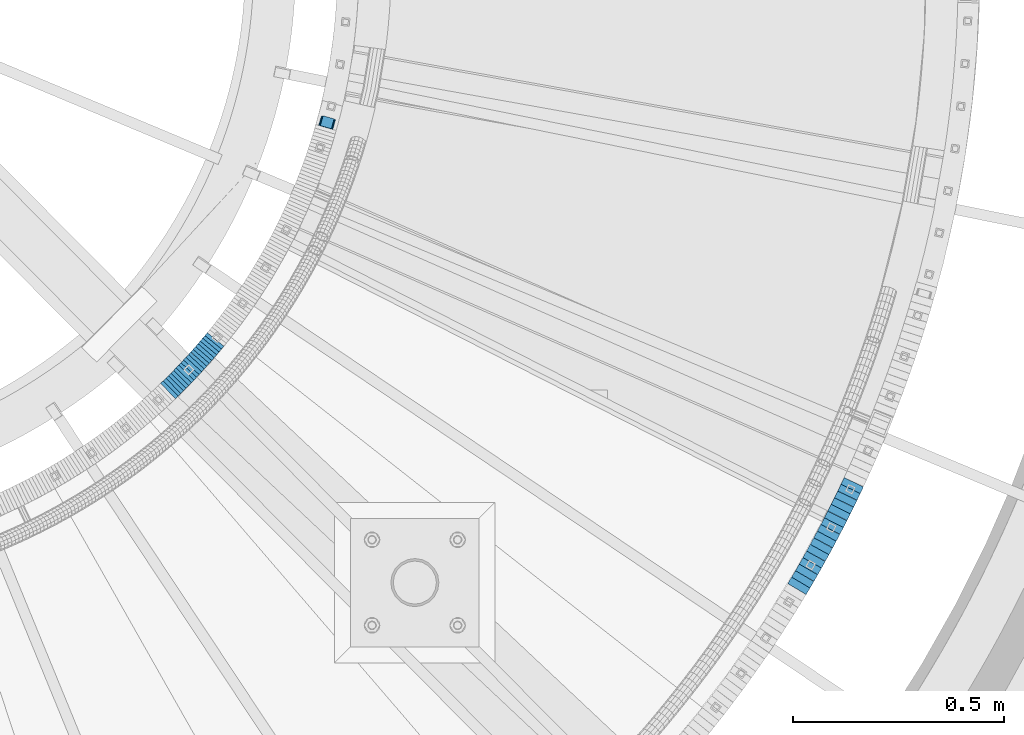
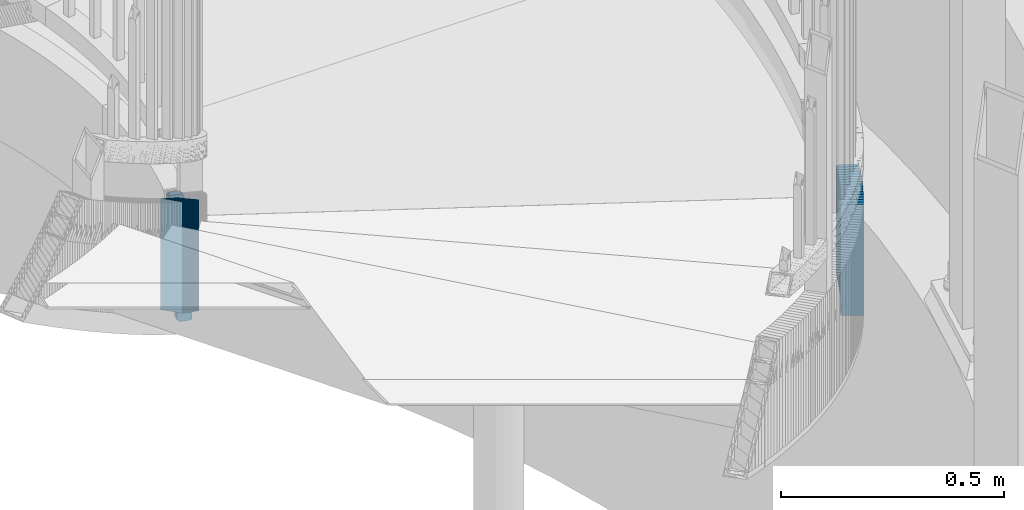
# One storey, part 906 of 975: 36 plates.
"""IFC2X3 building model written with IfcOpenShell, lengths in millimetres."""

from ifc_helpers import new_model, si_unit, frame, origin_with_axes, place, context, subcontext, project, spatial, faceted_brep, material, type_object, element, save


model = new_model("IFC2X3")

# Units and contexts
model_context = context("Model", 3, precision=1e-05, world=origin_with_axes())
body_context = subcontext(model_context, "Body", "Model", "MODEL_VIEW")
ifc_project = project(units=[si_unit("LENGTHUNIT", "METRE", prefix="MILLI"), si_unit("AREAUNIT", "SQUARE_METRE"), si_unit("VOLUMEUNIT", "CUBIC_METRE"), si_unit("MASSUNIT", "GRAM", prefix="KILO"), si_unit("TIMEUNIT", "SECOND"), si_unit("PLANEANGLEUNIT", "RADIAN"), si_unit("SOLIDANGLEUNIT", "STERADIAN"), si_unit("THERMODYNAMICTEMPERATUREUNIT", "DEGREE_CELSIUS"), si_unit("LUMINOUSINTENSITYUNIT", "LUMEN")], contexts=[model_context])

# Site, building, storey
site_placement = place(None, origin_with_axes())
site = spatial("IfcSite", under=ifc_project, at=site_placement, CompositionType="ELEMENT")
building_placement = place(site_placement, origin_with_axes())
building = spatial("IfcBuilding", under=site, at=building_placement, Name="Undefined", CompositionType="ELEMENT")
storey_placement = place(building_placement, origin_with_axes())
storey = spatial("IfcBuildingStorey", under=building, at=storey_placement, Name="Undefined", CompositionType="ELEMENT", Elevation=0.0)

# Plates
ifc_material = material(Name="STEEL/A36")
plate_type_1 = type_object("IfcPlateType", PredefinedType="NOTDEFINED")
plate_1_placement = place(storey_placement, frame((36098.5069484526, 3030.4815809635, 2176.46249923706), z_axis=(-0.0754792401712839, -0.266352390036721, -0.96091585928472), x_axis=(-0.962114570717468, 0.272645470919916, 0.0)))
element("IfcPlate", 1, at=plate_1_placement, inside=storey, type_object=plate_type_1, material=ifc_material, Name="PLATE", context=body_context, shape_type="Brep", body=[
    faceted_brep([(0.0340070923703024, -12.7000000000116, 6.3838263213047), (1.56807923502492, -12.7000000000517, 294.360523289424), (1.56807923496672, 12.6999999999643, 294.360523289415), (0.0340070923120948, 12.7000000000044, 6.38382632129469), (2.06110954808537, -12.7000000000498, 296.780155936494), (2.06110954803444, 12.699999999968, 296.780155936485), (3.4398364631852, -12.7000000000498, 298.828768425464), (3.43983646312699, 12.699999999968, 298.828768425454), (5.49576435648487, -12.700000000048, 300.1965628303), (5.49576435642666, 12.6999999999698, 300.196562830291), (7.91798904242751, -12.7000000000444, 300.676696777382), (7.91798904236202, 12.6999999999716, 300.676696777372), (30.141276409202, -12.7000000000244, 300.676696777376), (30.1412764091438, 12.6999999999916, 300.676696777366), (32.5791100484857, -12.7000000000207, 300.190097416452), (32.5791100484275, 12.6999999999953, 300.190097416442), (34.6433221732077, -12.7000000000189, 298.80487537828), (34.6433221731495, 12.6999999999971, 298.804875378271), (36.0175523689613, -12.7000000000189, 296.733329298654), (36.0175523688958, 12.6999999999989, 296.733329298644), (36.4911866057737, -12.7000000000171, 294.292943591306), (36.4911866057228, 12.7000000000007, 294.292943591297), (34.9604313355012, -12.6999999999789, 6.3162466231588), (34.9604313354357, 12.7000000000389, 6.31624662314971), (34.4674218263681, -12.6999999999771, 3.89659143350127), (34.4674218263099, 12.7000000000371, 3.89659143349127), (33.0886996444533, -12.6999999999789, 1.84795414056771), (33.0886996443878, 12.7000000000371, 1.84795414055861), (31.0327627264342, -12.6999999999807, 0.480140921574275), (31.0327627263759, 12.7000000000353, 0.480140921564271), (28.6105211389149, -12.6999999999825, -3.72892827726901e-11), (28.6105211388567, 12.7000000000317, -4.63842297904193e-11), (6.38391689976561, -12.7000000000044, -4.54747350886464e-12), (6.3839168997074, 12.7000000000116, -1.45519152283669e-11), (3.9460663775244, -12.700000000008, 0.486606380397461), (3.9460663774662, 12.7000000000098, 0.486606380388366), (1.88184534707398, -12.700000000008, 1.87184732537662), (1.88184534700849, 12.700000000008, 1.87184732536753), (0.507620151394804, -12.7000000000116, 3.94341823891864), (0.507620151343872, 12.7000000000044, 3.94341823890954)], [[[0, 1, 2, 3]], [[1, 4, 5, 2]], [[4, 6, 7, 5]], [[6, 8, 9, 7]], [[8, 10, 11, 9]], [[10, 12, 13, 11]], [[12, 14, 15, 13]], [[14, 16, 17, 15]], [[16, 18, 19, 17]], [[18, 20, 21, 19]], [[20, 22, 23, 21]], [[22, 24, 25, 23]], [[24, 26, 27, 25]], [[26, 28, 29, 27]], [[28, 30, 31, 29]], [[30, 32, 33, 31]], [[32, 34, 35, 33]], [[34, 36, 37, 35]], [[36, 38, 39, 37]], [[38, 0, 3, 39]], [[5, 7, 9, 11, 13, 15, 17, 19, 21, 23, 25, 27, 29, 31, 33, 35, 37, 39, 3, 2]], [[38, 36, 34, 32, 30, 28, 26, 24, 22, 20, 18, 16, 14, 12, 10, 8, 6, 4, 1, 0]]]),
])
plate_type_2 = type_object("IfcPlateType", PredefinedType="NOTDEFINED")
for number, where, z_axis, x_axis, name in (
    (2, (37205.6589783962, 1942.78051607344, 2116.38750006771), (-0.508729312126642, -0.860926528214315, 0.0), (0.0, 0.0, 1.0), "WALL"),
    (3, (37214.7589783982, 1958.18051607357, 2110.68750006771), (-0.508729312126642, -0.860926528214315, 0.0), (0.0, 0.0, 1.0), "WALL"),
):
    element("IfcPlate", number, at=place(storey_placement, frame(where, z_axis=z_axis, x_axis=x_axis)), inside=storey, type_object=plate_type_2, material=ifc_material, Name=name, context=body_context, shape_type="Brep", body=[
        faceted_brep([(0.0, -25.3999999999724, -1.81898940354586e-11), (5.69999980926514, -25.3999999999614, 17.8921775817616), (5.69999980926514, 25.400000000016, 17.8921775817726), (0.0, 25.3999999999869, 1.45519152283669e-11), (310.5, -25.3999999999614, 17.8921775817616), (310.5, 25.400000000016, 17.8921775817726), (304.799987792969, -25.3999999999724, -1.81898940354586e-11), (304.799987792969, 25.3999999999869, 1.45519152283669e-11)], [[[0, 1, 2, 3]], [[1, 4, 5, 2]], [[4, 6, 7, 5]], [[6, 0, 3, 7]], [[5, 7, 3, 2]], [[6, 4, 1, 0]]]),
    ])
plate_2_placement = place(storey_placement, frame((37223.8185368546, 1973.95442632196, 2104.88750006771), z_axis=(-0.497945444086888, -0.867208357151332, 0.0), x_axis=(0.0, 0.0, 1.0)))
element("IfcPlate", 4, at=plate_2_placement, inside=storey, type_object=plate_type_2, material=ifc_material, Name="WALL", context=body_context, shape_type="Brep", body=[
    faceted_brep([(0.0, -25.3999999999724, -1.81898940354586e-11), (5.80000019073486, -25.3999999999705, 17.873443603421), (5.80000019073486, 25.3999999999924, 17.8734436035338), (0.0, 25.3999999999869, 1.45519152283669e-11), (310.600006103516, -25.3999999999705, 17.873443603421), (310.600006103516, 25.3999999999924, 17.8734436035338), (304.799987792969, -25.3999999999724, -1.81898940354586e-11), (304.799987792969, 25.3999999999869, 1.45519152283669e-11)], [[[0, 1, 2, 3]], [[1, 4, 5, 2]], [[4, 6, 7, 5]], [[6, 0, 3, 7]], [[5, 7, 3, 2]], [[6, 4, 1, 0]]]),
])
plate_3_placement = place(storey_placement, frame((37232.6798132569, 1989.56174742001, 2099.18750006771), z_axis=(-0.493720204004981, -0.869620814008772, 0.0), x_axis=(0.0, 0.0, 1.0)))
element("IfcPlate", 5, at=plate_3_placement, inside=storey, type_object=plate_type_2, material=ifc_material, Name="WALL", context=body_context, shape_type="Brep", body=[
    faceted_brep([(0.0, -25.3999999999724, -1.81898940354586e-11), (5.69999980926514, -25.3999999999432, 17.8213348388126), (5.69999980926514, 25.3999999999905, 17.8213348388708), (0.0, 25.3999999999869, 1.45519152283669e-11), (310.5, -25.3999999999432, 17.8213348388126), (310.5, 25.3999999999905, 17.8213348388708), (304.799987792969, -25.3999999999724, -1.81898940354586e-11), (304.799987792969, 25.3999999999869, 1.45519152283669e-11)], [[[0, 1, 2, 3]], [[1, 4, 5, 2]], [[4, 6, 7, 5]], [[6, 0, 3, 7]], [[5, 7, 3, 2]], [[6, 4, 1, 0]]]),
])
plate_4_placement = place(storey_placement, frame((37241.5142976609, 2005.22268245497, 2093.48750006771), z_axis=(-0.491321186873553, -0.870978467775847, 0.0), x_axis=(0.0, 0.0, 1.0)))
element("IfcPlate", 6, at=plate_4_placement, inside=storey, type_object=plate_type_2, material=ifc_material, Name="WALL", context=body_context, shape_type="Brep", body=[
    faceted_brep([(0.0, -25.3999999999724, -1.81898940354586e-11), (5.69999980926514, -25.4000000000633, 17.9075393677485), (5.69999980926514, 25.3999999999905, 17.9075393676903), (0.0, 25.3999999999869, 1.45519152283669e-11), (310.5, -25.4000000000633, 17.9075393677485), (310.5, 25.3999999999905, 17.9075393676903), (304.799987792969, -25.3999999999724, -1.81898940354586e-11), (304.799987792969, 25.3999999999869, 1.45519152283669e-11)], [[[0, 1, 2, 3]], [[1, 4, 5, 2]], [[4, 6, 7, 5]], [[6, 0, 3, 7]], [[5, 7, 3, 2]], [[6, 4, 1, 0]]]),
])
plate_5_placement = place(storey_placement, frame((37250.2682663921, 2021.19965030317, 2087.68750006771), z_axis=(-0.480416940883703, -0.877040228787679, 0.0), x_axis=(0.0, 0.0, 1.0)))
element("IfcPlate", 7, at=plate_5_placement, inside=storey, type_object=plate_type_2, material=ifc_material, Name="WALL", context=body_context, shape_type="Brep", body=[
    faceted_brep([(0.0, -25.3999999999724, -1.81898940354586e-11), (5.80000019073486, -25.399999999936, 17.9011173247382), (5.80000019073486, 25.3999999999578, 17.9011173248837), (0.0, 25.3999999999869, 1.45519152283669e-11), (310.600006103516, -25.399999999936, 17.9011173247382), (310.600006103516, 25.3999999999578, 17.9011173248837), (304.799987792969, -25.3999999999724, -1.81898940354586e-11), (304.799987792969, 25.3999999999869, 1.45519152283669e-11)], [[[0, 1, 2, 3]], [[1, 4, 5, 2]], [[4, 6, 7, 5]], [[6, 0, 3, 7]], [[5, 7, 3, 2]], [[6, 4, 1, 0]]]),
])
plate_6_placement = place(storey_placement, frame((37258.8682663934, 2036.8996503033, 2081.98750006771), z_axis=(-0.480416940883703, -0.877040228787679, 0.0), x_axis=(0.0, 0.0, 1.0)))
element("IfcPlate", 8, at=plate_6_placement, inside=storey, type_object=plate_type_2, material=ifc_material, Name="WALL", context=body_context, shape_type="Brep", body=[
    faceted_brep([(0.0, -25.3999999999724, -1.81898940354586e-11), (5.69999980926514, -25.3999999999978, 17.9011173248218), (5.69999980926514, 25.4000000000087, 17.9011173248182), (0.0, 25.3999999999869, 1.45519152283669e-11), (310.5, -25.3999999999978, 17.9011173248218), (310.5, 25.4000000000087, 17.9011173248182), (304.799987792969, -25.3999999999724, -1.81898940354586e-11), (304.799987792969, 25.3999999999869, 1.45519152283669e-11)], [[[0, 1, 2, 3]], [[1, 4, 5, 2]], [[4, 6, 7, 5]], [[6, 0, 3, 7]], [[5, 7, 3, 2]], [[6, 4, 1, 0]]]),
])
plate_7_placement = place(storey_placement, frame((37267.4189071129, 2052.97877951288, 2076.18750006771), z_axis=(-0.469427601925258, -0.882970965859411, 0.0), x_axis=(0.0, 0.0, 1.0)))
element("IfcPlate", 9, at=plate_7_placement, inside=storey, type_object=plate_type_2, material=ifc_material, Name="WALL", context=body_context, shape_type="Brep", body=[
    faceted_brep([(0.0, -25.3999999999724, -1.81898940354586e-11), (5.80000019073486, -25.4000000000451, 17.8891029358201), (5.80000019073486, 25.4000000000087, 17.8891029357856), (0.0, 25.3999999999869, 1.45519152283669e-11), (310.600006103516, -25.4000000000451, 17.8891029358201), (310.600006103516, 25.4000000000087, 17.8891029357856), (304.799987792969, -25.3999999999724, -1.81898940354586e-11), (304.799987792969, 25.3999999999869, 1.45519152283669e-11)], [[[0, 1, 2, 3]], [[1, 4, 5, 2]], [[4, 6, 7, 5]], [[6, 0, 3, 7]], [[5, 7, 3, 2]], [[6, 4, 1, 0]]]),
])
for number, where, z_axis, x_axis, name in (
    (10, (37275.8189071109, 2068.77877951299, 2070.48750006771), (-0.469427601925258, -0.882970965859411, 0.0), (0.0, 0.0, 1.0), "WALL"),
    (11, (37284.1661413293, 2084.95994415503, 2064.78750006771), (-0.458358127825704, -0.888767588662028, 0.0), (0.0, 0.0, 1.0), "WALL"),
):
    element("IfcPlate", number, at=place(storey_placement, frame(where, z_axis=z_axis, x_axis=x_axis)), inside=storey, type_object=plate_type_2, material=ifc_material, Name=name, context=body_context, shape_type="Brep", body=[
        faceted_brep([(0.0, -25.3999999999724, -1.81898940354586e-11), (5.69999980926514, -25.3999999999614, 17.8921775817616), (5.69999980926514, 25.400000000016, 17.8921775817726), (0.0, 25.3999999999869, 1.45519152283669e-11), (310.5, -25.3999999999614, 17.8921775817616), (310.5, 25.400000000016, 17.8921775817726), (304.799987792969, -25.3999999999724, -1.81898940354586e-11), (304.799987792969, 25.3999999999869, 1.45519152283669e-11)], [[[0, 1, 2, 3]], [[1, 4, 5, 2]], [[4, 6, 7, 5]], [[6, 0, 3, 7]], [[5, 7, 3, 2]], [[6, 4, 1, 0]]]),
    ])
plate_8_placement = place(storey_placement, frame((37292.3957491425, 2101.01753451545, 2058.98750006771), z_axis=(-0.4560907908015, -0.889933250612686, 0.0), x_axis=(0.0, 0.0, 1.0)))
element("IfcPlate", 12, at=plate_8_placement, inside=storey, type_object=plate_type_2, material=ifc_material, Name="WALL", context=body_context, shape_type="Brep", body=[
    faceted_brep([(0.0, -25.3999999999724, -1.81898940354586e-11), (5.80000019073486, -25.3999999999505, 17.9788761138298), (5.80000019073486, 25.4000000000196, 17.9788761138625), (0.0, 25.3999999999869, 1.45519152283669e-11), (310.600006103516, -25.3999999999505, 17.9788761138298), (310.600006103516, 25.4000000000196, 17.9788761138625), (304.799987792969, -25.3999999999724, -1.81898940354586e-11), (304.799987792969, 25.3999999999869, 1.45519152283669e-11)], [[[0, 1, 2, 3]], [[1, 4, 5, 2]], [[4, 6, 7, 5]], [[6, 0, 3, 7]], [[5, 7, 3, 2]], [[6, 4, 1, 0]]]),
])
plate_9_placement = place(storey_placement, frame((37300.4098952232, 2117.04301526588, 2053.28750006771), z_axis=(-0.447213595899957, -0.894427190799916, 0.0), x_axis=(0.0, 0.0, 1.0)))
element("IfcPlate", 13, at=plate_9_placement, inside=storey, type_object=plate_type_2, material=ifc_material, Name="WALL", context=body_context, shape_type="Brep", body=[
    faceted_brep([(0.0, -25.3999999999724, -1.81898940354586e-11), (5.69999980926514, -25.3999999999214, 17.6649379730588), (5.69999980926514, 25.3999999999323, 17.6649379729861), (0.0, 25.3999999999869, 1.45519152283669e-11), (310.5, -25.3999999999214, 17.6649379730588), (310.5, 25.3999999999323, 17.6649379729861), (304.799987792969, -25.3999999999724, -1.81898940354586e-11), (304.799987792969, 25.3999999999869, 1.45519152283669e-11)], [[[0, 1, 2, 3]], [[1, 4, 5, 2]], [[4, 6, 7, 5]], [[6, 0, 3, 7]], [[5, 7, 3, 2]], [[6, 4, 1, 0]]]),
])
plate_10_placement = place(storey_placement, frame((37308.3098952231, 2132.84301526583, 2047.68750006771), z_axis=(-0.447213595899957, -0.894427190799916, 0.0), x_axis=(0.0, 0.0, 1.0)))
element("IfcPlate", 14, at=plate_10_placement, inside=storey, type_object=plate_type_2, material=ifc_material, Name="WALL", context=body_context, shape_type="Brep", body=[
    faceted_brep([(0.0, -25.3999999999724, -1.81898940354586e-11), (5.59999990463257, -25.3999999999905, 17.6581420898401), (5.59999990463257, 25.4000000000196, 17.6581420898292), (0.0, 25.3999999999869, 1.45519152283669e-11), (310.399993896484, -25.3999999999905, 17.6581420898401), (310.399993896484, 25.4000000000196, 17.6581420898292), (304.799987792969, -25.3999999999724, -1.81898940354586e-11), (304.799987792969, 25.3999999999869, 1.45519152283669e-11)], [[[0, 1, 2, 3]], [[1, 4, 5, 2]], [[4, 6, 7, 5]], [[6, 0, 3, 7]], [[5, 7, 3, 2]], [[6, 4, 1, 0]]]),
])
plate_11_placement = place(storey_placement, frame((37316.124328103, 2148.87482266969, 2041.98750006771), z_axis=(-0.438087320160434, -0.898932422329204, 0.0), x_axis=(0.0, 0.0, 1.0)))
element("IfcPlate", 15, at=plate_11_placement, inside=storey, type_object=plate_type_2, material=ifc_material, Name="WALL", context=body_context, shape_type="Brep", body=[
    faceted_brep([(0.0, -25.3999999999724, -1.81898940354586e-11), (5.69999980926514, -25.4000000000269, 17.5764045715187), (5.69999980926514, 25.3999999999869, 17.5764045715332), (0.0, 25.3999999999869, 1.45519152283669e-11), (310.5, -25.4000000000269, 17.5764045715187), (310.5, 25.3999999999869, 17.5764045715332), (304.799987792969, -25.3999999999724, -1.81898940354586e-11), (304.799987792969, 25.3999999999869, 1.45519152283669e-11)], [[[0, 1, 2, 3]], [[1, 4, 5, 2]], [[4, 6, 7, 5]], [[6, 0, 3, 7]], [[5, 7, 3, 2]], [[6, 4, 1, 0]]]),
])
plate_12_placement = place(storey_placement, frame((37323.8346931815, 2165.10419749924, 2036.38750006771), z_axis=(-0.429056815057839, -0.903277504121753, 0.0), x_axis=(0.0, 0.0, 1.0)))
element("IfcPlate", 16, at=plate_12_placement, inside=storey, type_object=plate_type_2, material=ifc_material, Name="WALL", context=body_context, shape_type="Brep", body=[
    faceted_brep([(0.0, -25.3999999999724, -1.81898940354586e-11), (5.59999990463257, -25.4000000000087, 17.710166931156), (5.59999990463257, 25.399999999976, 17.7101669311705), (0.0, 25.3999999999869, 1.45519152283669e-11), (310.399993896484, -25.4000000000087, 17.710166931156), (310.399993896484, 25.399999999976, 17.7101669311705), (304.799987792969, -25.3999999999724, -1.81898940354586e-11), (304.799987792969, 25.3999999999869, 1.45519152283669e-11)], [[[0, 1, 2, 3]], [[1, 4, 5, 2]], [[4, 6, 7, 5]], [[6, 0, 3, 7]], [[5, 7, 3, 2]], [[6, 4, 1, 0]]]),
])
plate_13_placement = place(storey_placement, frame((37331.4080923616, 2180.94837122509, 2030.68750006771), z_axis=(-0.431254699872989, -0.902230227734284, 0.0), x_axis=(0.0, 0.0, 1.0)))
element("IfcPlate", 17, at=plate_13_placement, inside=storey, type_object=plate_type_2, material=ifc_material, Name="WALL", context=body_context, shape_type="Brep", body=[
    faceted_brep([(0.0, -25.3999999999724, -1.81898940354586e-11), (5.69999980926514, -25.4000000001142, 17.6229972838883), (5.69999980926514, 25.4000000000233, 17.6229972839465), (0.0, 25.3999999999869, 1.45519152283669e-11), (310.5, -25.4000000001142, 17.6229972838883), (310.5, 25.4000000000233, 17.6229972839465), (304.799987792969, -25.3999999999724, -1.81898940354586e-11), (304.799987792969, 25.3999999999869, 1.45519152283669e-11)], [[[0, 1, 2, 3]], [[1, 4, 5, 2]], [[4, 6, 7, 5]], [[6, 0, 3, 7]], [[5, 7, 3, 2]], [[6, 4, 1, 0]]]),
])
plate_type_3 = type_object("IfcPlateType", PredefinedType="NOTDEFINED")
plate_14_placement = place(storey_placement, frame((35710.1920324392, 2403.51723130574, 2365.12500005033), z_axis=(-0.718240222804792, -0.695795215810889, 0.0), x_axis=(0.0, 0.0, 1.0)))
element("IfcPlate", 18, at=plate_14_placement, inside=storey, type_object=plate_type_3, material=ifc_material, Name="WALL", context=body_context, shape_type="Brep", body=[
    faceted_brep([(0.0, -25.3999999999724, -1.81898940354586e-11), (5.69999980926514, -25.4000000000269, 8.91066741947361), (5.69999980926514, 25.4000000000269, 8.91066741941904), (0.0, 25.3999999999869, 1.45519152283669e-11), (310.5, -25.4000000000269, 8.91066741947361), (310.5, 25.4000000000269, 8.91066741941904), (304.799987792969, -25.3999999999724, -1.81898940354586e-11), (304.799987792969, 25.3999999999869, 1.45519152283669e-11)], [[[0, 1, 2, 3]], [[1, 4, 5, 2]], [[4, 6, 7, 5]], [[6, 0, 3, 7]], [[5, 7, 3, 2]], [[6, 4, 1, 0]]]),
])
plate_15_placement = place(storey_placement, frame((35716.4466923953, 2409.67530210146, 2359.42500005033), z_axis=(-0.712652458853255, -0.701517264855549, 0.0), x_axis=(0.0, 0.0, 1.0)))
element("IfcPlate", 19, at=plate_15_placement, inside=storey, type_object=plate_type_3, material=ifc_material, Name="WALL", context=body_context, shape_type="Brep", body=[
    faceted_brep([(0.0, -25.3999999999724, -1.81898940354586e-11), (5.69999980926514, -25.3999999999542, 8.98276138300935), (5.69999980926514, 25.3999999999614, 8.98276138309302), (0.0, 25.3999999999869, 1.45519152283669e-11), (310.5, -25.3999999999542, 8.98276138300935), (310.5, 25.3999999999614, 8.98276138309302), (304.799987792969, -25.3999999999724, -1.81898940354586e-11), (304.799987792969, 25.3999999999869, 1.45519152283669e-11)], [[[0, 1, 2, 3]], [[1, 4, 5, 2]], [[4, 6, 7, 5]], [[6, 0, 3, 7]], [[5, 7, 3, 2]], [[6, 4, 1, 0]]]),
])
plate_16_placement = place(storey_placement, frame((35722.6047186813, 2415.83444188882, 2353.72500005033), z_axis=(-0.707106781186548, -0.707106781186548, 0.0), x_axis=(0.0, 0.0, 1.0)))
element("IfcPlate", 20, at=plate_16_placement, inside=storey, type_object=plate_type_3, material=ifc_material, Name="WALL", context=body_context, shape_type="Brep", body=[
    faceted_brep([(0.0, -25.3999999999724, -1.81898940354586e-11), (5.69999980926514, -25.4000000000269, 8.91066741947361), (5.69999980926514, 25.4000000000269, 8.91066741941904), (0.0, 25.3999999999869, 1.45519152283669e-11), (310.5, -25.4000000000269, 8.91066741947361), (310.5, 25.4000000000269, 8.91066741941904), (304.799987792969, -25.3999999999724, -1.81898940354586e-11), (304.799987792969, 25.3999999999869, 1.45519152283669e-11)], [[[0, 1, 2, 3]], [[1, 4, 5, 2]], [[4, 6, 7, 5]], [[6, 0, 3, 7]], [[5, 7, 3, 2]], [[6, 4, 1, 0]]]),
])
plate_17_placement = place(storey_placement, frame((35728.9047186822, 2422.13444188894, 2347.92500005033), z_axis=(-0.707106781186548, -0.707106781186548, 0.0), x_axis=(0.0, 0.0, 1.0)))
element("IfcPlate", 21, at=plate_17_placement, inside=storey, type_object=plate_type_3, material=ifc_material, Name="WALL", context=body_context, shape_type="Brep", body=[
    faceted_brep([(0.0, -25.3999999999724, -1.81898940354586e-11), (5.80000019073486, -25.3999999999796, 8.91403388975959), (5.80000019073486, 25.3999999999432, 8.91403388980689), (0.0, 25.3999999999869, 1.45519152283669e-11), (310.600006103515, -25.3999999999796, 8.91403388975959), (310.600006103515, 25.3999999999432, 8.91403388980689), (304.799987792969, -25.3999999999724, -1.81898940354586e-11), (304.799987792969, 25.3999999999869, 1.45519152283669e-11)], [[[0, 1, 2, 3]], [[1, 4, 5, 2]], [[4, 6, 7, 5]], [[6, 0, 3, 7]], [[5, 7, 3, 2]], [[6, 4, 1, 0]]]),
])
plate_18_placement = place(storey_placement, frame((35735.0638584724, 2428.3924681742, 2342.22500005033), z_axis=(-0.701517264855551, -0.712652458853252, 0.0), x_axis=(0.0, 0.0, 1.0)))
element("IfcPlate", 22, at=plate_18_placement, inside=storey, type_object=plate_type_3, material=ifc_material, Name="WALL", context=body_context, shape_type="Brep", body=[
    faceted_brep([(0.0, -25.3999999999724, -1.81898940354586e-11), (5.69999980926514, -25.3999999999542, 8.98276138300935), (5.69999980926514, 25.3999999999614, 8.98276138309302), (0.0, 25.3999999999869, 1.45519152283669e-11), (310.5, -25.3999999999542, 8.98276138300935), (310.5, 25.3999999999614, 8.98276138309302), (304.799987792969, -25.3999999999724, -1.81898940354586e-11), (304.799987792969, 25.3999999999869, 1.45519152283669e-11)], [[[0, 1, 2, 3]], [[1, 4, 5, 2]], [[4, 6, 7, 5]], [[6, 0, 3, 7]], [[5, 7, 3, 2]], [[6, 4, 1, 0]]]),
])
plate_19_placement = place(storey_placement, frame((35741.1219292689, 2434.64712812868, 2336.52500005033), z_axis=(-0.69579521581089, -0.718240222804792, 0.0), x_axis=(0.0, 0.0, 1.0)))
element("IfcPlate", 23, at=plate_19_placement, inside=storey, type_object=plate_type_3, material=ifc_material, Name="WALL", context=body_context, shape_type="Brep", body=[
    faceted_brep([(0.0, -25.3999999999724, -1.81898940354586e-11), (5.69999980926514, -25.4000000000269, 8.91066741947361), (5.69999980926514, 25.4000000000269, 8.91066741941904), (0.0, 25.3999999999869, 1.45519152283669e-11), (310.5, -25.4000000000269, 8.91066741947361), (310.5, 25.4000000000269, 8.91066741941904), (304.799987792969, -25.3999999999724, -1.81898940354586e-11), (304.799987792969, 25.3999999999869, 1.45519152283669e-11)], [[[0, 1, 2, 3]], [[1, 4, 5, 2]], [[4, 6, 7, 5]], [[6, 0, 3, 7]], [[5, 7, 3, 2]], [[6, 4, 1, 0]]]),
])
plate_20_placement = place(storey_placement, frame((35747.3219292698, 2441.04712812888, 2330.72500005033), z_axis=(-0.69579521581089, -0.718240222804792, 0.0), x_axis=(0.0, 0.0, 1.0)))
element("IfcPlate", 24, at=plate_20_placement, inside=storey, type_object=plate_type_3, material=ifc_material, Name="WALL", context=body_context, shape_type="Brep", body=[
    faceted_brep([(0.0, -25.3999999999724, -1.81898940354586e-11), (5.80000019073486, -25.3999999999796, 8.91403388975959), (5.80000019073486, 25.3999999999432, 8.91403388980689), (0.0, 25.3999999999869, 1.45519152283669e-11), (310.600006103515, -25.3999999999796, 8.91403388975959), (310.600006103515, 25.3999999999432, 8.91403388980689), (304.799987792969, -25.3999999999724, -1.81898940354586e-11), (304.799987792969, 25.3999999999869, 1.45519152283669e-11)], [[[0, 1, 2, 3]], [[1, 4, 5, 2]], [[4, 6, 7, 5]], [[6, 0, 3, 7]], [[5, 7, 3, 2]], [[6, 4, 1, 0]]]),
])
plate_21_placement = place(storey_placement, frame((35753.1438743494, 2447.25551042742, 2325.02500005033), z_axis=(-0.684314203948307, -0.729187266944915, 0.0), x_axis=(0.0, 0.0, 1.0)))
element("IfcPlate", 25, at=plate_21_placement, inside=storey, type_object=plate_type_3, material=ifc_material, Name="WALL", context=body_context, shape_type="Brep", body=[
    faceted_brep([(0.0, -25.3999999999724, -1.81898940354586e-11), (5.69999980926514, -25.4000000000269, 8.91066741947361), (5.69999980926514, 25.4000000000269, 8.91066741941904), (0.0, 25.3999999999869, 1.45519152283669e-11), (310.5, -25.4000000000269, 8.91066741947361), (310.5, 25.4000000000269, 8.91066741941904), (304.799987792969, -25.3999999999724, -1.81898940354586e-11), (304.799987792969, 25.3999999999869, 1.45519152283669e-11)], [[[0, 1, 2, 3]], [[1, 4, 5, 2]], [[4, 6, 7, 5]], [[6, 0, 3, 7]], [[5, 7, 3, 2]], [[6, 4, 1, 0]]]),
])
plate_22_placement = place(storey_placement, frame((35759.1120625433, 2453.7139792175, 2319.32500005033), z_axis=(-0.678742109073749, -0.734376708079797, 0.0), x_axis=(0.0, 0.0, 1.0)))
element("IfcPlate", 26, at=plate_22_placement, inside=storey, type_object=plate_type_3, material=ifc_material, Name="WALL", context=body_context, shape_type="Brep", body=[
    faceted_brep([(0.0, -25.3999999999724, -1.81898940354586e-11), (5.69999980926514, -25.4000000000196, 8.98721313477654), (5.69999980926514, 25.4000000000669, 8.98721313470742), (0.0, 25.3999999999869, 1.45519152283669e-11), (310.5, -25.4000000000196, 8.98721313477654), (310.5, 25.4000000000669, 8.98721313470742), (304.799987792969, -25.3999999999724, -1.81898940354586e-11), (304.799987792969, 25.3999999999869, 1.45519152283669e-11)], [[[0, 1, 2, 3]], [[1, 4, 5, 2]], [[4, 6, 7, 5]], [[6, 0, 3, 7]], [[5, 7, 3, 2]], [[6, 4, 1, 0]]]),
])
plate_23_placement = place(storey_placement, frame((35765.1012234358, 2460.20224425533, 2313.52500005033), z_axis=(-0.678280102691532, -0.734803444665827, 0.0), x_axis=(0.0, 0.0, 1.0)))
element("IfcPlate", 27, at=plate_23_placement, inside=storey, type_object=plate_type_3, material=ifc_material, Name="WALL", context=body_context, shape_type="Brep", body=[
    faceted_brep([(0.0, -25.3999999999724, -1.81898940354586e-11), (5.80000019073486, -25.4000000000378, 8.84590339667557), (5.80000019073486, 25.4000000000415, 8.8459033965446), (0.0, 25.3999999999869, 1.45519152283669e-11), (310.600006103516, -25.4000000000378, 8.84590339667557), (310.600006103516, 25.4000000000415, 8.8459033965446), (304.799987792969, -25.3999999999724, -1.81898940354586e-11), (304.799987792969, 25.3999999999869, 1.45519152283669e-11)], [[[0, 1, 2, 3]], [[1, 4, 5, 2]], [[4, 6, 7, 5]], [[6, 0, 3, 7]], [[5, 7, 3, 2]], [[6, 4, 1, 0]]]),
])
plate_24_placement = place(storey_placement, frame((35771.2120625439, 2466.81397921745, 2307.82500005033), z_axis=(-0.678742109073749, -0.734376708079797, 0.0), x_axis=(0.0, 0.0, 1.0)))
element("IfcPlate", 28, at=plate_24_placement, inside=storey, type_object=plate_type_3, material=ifc_material, Name="WALL", context=body_context, shape_type="Brep", body=[
    faceted_brep([(0.0, -25.3999999999724, -1.81898940354586e-11), (5.69999980926514, -25.4000000000196, 8.98721313477654), (5.69999980926514, 25.4000000000669, 8.98721313470742), (0.0, 25.3999999999869, 1.45519152283669e-11), (310.5, -25.4000000000196, 8.98721313477654), (310.5, 25.4000000000669, 8.98721313470742), (304.799987792969, -25.3999999999724, -1.81898940354586e-11), (304.799987792969, 25.3999999999869, 1.45519152283669e-11)], [[[0, 1, 2, 3]], [[1, 4, 5, 2]], [[4, 6, 7, 5]], [[6, 0, 3, 7]], [[5, 7, 3, 2]], [[6, 4, 1, 0]]]),
])
plate_25_placement = place(storey_placement, frame((35776.702752794, 2473.06029099707, 2302.12500005033), z_axis=(-0.660880368115947, -0.750491265131667, 0.0), x_axis=(0.0, 0.0, 1.0)))
element("IfcPlate", 29, at=plate_25_placement, inside=storey, type_object=plate_type_3, material=ifc_material, Name="WALL", context=body_context, shape_type="Brep", body=[
    faceted_brep([(0.0, -25.3999999999724, -1.81898940354586e-11), (5.69999980926514, -25.3999999999542, 8.93084526058738), (5.69999980926514, 25.3999999999178, 8.93084526067832), (0.0, 25.3999999999869, 1.45519152283669e-11), (310.5, -25.3999999999542, 8.93084526058738), (310.5, 25.3999999999178, 8.93084526067832), (304.799987792969, -25.3999999999724, -1.81898940354586e-11), (304.799987792969, 25.3999999999869, 1.45519152283669e-11)], [[[0, 1, 2, 3]], [[1, 4, 5, 2]], [[4, 6, 7, 5]], [[6, 0, 3, 7]], [[5, 7, 3, 2]], [[6, 4, 1, 0]]]),
])
plate_26_placement = place(storey_placement, frame((35782.8434895721, 2479.91877264271, 2296.42500005033), z_axis=(-0.667119802986571, -0.744950446985005, 0.0), x_axis=(0.0, 0.0, 1.0)))
element("IfcPlate", 30, at=plate_26_placement, inside=storey, type_object=plate_type_3, material=ifc_material, Name="WALL", context=body_context, shape_type="Brep", body=[
    faceted_brep([(0.0, -25.3999999999724, -1.81898940354586e-11), (5.69999980926514, -25.4000000000196, 8.98721313477654), (5.69999980926514, 25.4000000000669, 8.98721313470742), (0.0, 25.3999999999869, 1.45519152283669e-11), (310.5, -25.4000000000196, 8.98721313477654), (310.5, 25.4000000000669, 8.98721313470742), (304.799987792969, -25.3999999999724, -1.81898940354586e-11), (304.799987792969, 25.3999999999869, 1.45519152283669e-11)], [[[0, 1, 2, 3]], [[1, 4, 5, 2]], [[4, 6, 7, 5]], [[6, 0, 3, 7]], [[5, 7, 3, 2]], [[6, 4, 1, 0]]]),
])
plate_27_placement = place(storey_placement, frame((35788.3612741142, 2486.2982504695, 2290.62500005033), z_axis=(-0.65450081979011, -0.756061291757536, 0.0), x_axis=(0.0, 0.0, 1.0)))
element("IfcPlate", 31, at=plate_27_placement, inside=storey, type_object=plate_type_3, material=ifc_material, Name="WALL", context=body_context, shape_type="Brep", body=[
    faceted_brep([(0.0, -25.3999999999724, -1.81898940354586e-11), (5.80000019073486, -25.4000000000106, 8.86171531681612), (5.80000019073486, 25.4000000000015, 8.86171531675791), (0.0, 25.3999999999869, 1.45519152283669e-11), (310.600006103516, -25.4000000000106, 8.86171531681612), (310.600006103516, 25.4000000000015, 8.86171531675791), (304.799987792969, -25.3999999999724, -1.81898940354586e-11), (304.799987792969, 25.3999999999869, 1.45519152283669e-11)], [[[0, 1, 2, 3]], [[1, 4, 5, 2]], [[4, 6, 7, 5]], [[6, 0, 3, 7]], [[5, 7, 3, 2]], [[6, 4, 1, 0]]]),
])
plate_28_placement = place(storey_placement, frame((35794.2800402553, 2493.11990390472, 2284.92500005033), z_axis=(-0.655353317243179, -0.755322467280275, 0.0), x_axis=(0.0, 0.0, 1.0)))
element("IfcPlate", 32, at=plate_28_placement, inside=storey, type_object=plate_type_3, material=ifc_material, Name="WALL", context=body_context, shape_type="Brep", body=[
    faceted_brep([(0.0, -25.3999999999724, -1.81898940354586e-11), (5.69999980926514, -25.3999999999978, 9.00277709959482), (5.69999980926514, 25.3999999999651, 9.00277709966031), (0.0, 25.3999999999869, 1.45519152283669e-11), (310.5, -25.3999999999978, 9.00277709959482), (310.5, 25.3999999999651, 9.00277709966031), (304.799987792969, -25.3999999999724, -1.81898940354586e-11), (304.799987792969, 25.3999999999869, 1.45519152283669e-11)], [[[0, 1, 2, 3]], [[1, 4, 5, 2]], [[4, 6, 7, 5]], [[6, 0, 3, 7]], [[5, 7, 3, 2]], [[6, 4, 1, 0]]]),
])
plate_29_placement = place(storey_placement, frame((35799.9400485437, 2499.75717343946, 2279.22500005033), z_axis=(-0.648946606014645, -0.760833952017175, 0.0), x_axis=(0.0, 0.0, 1.0)))
element("IfcPlate", 33, at=plate_29_placement, inside=storey, type_object=plate_type_3, material=ifc_material, Name="WALL", context=body_context, shape_type="Brep", body=[
    faceted_brep([(0.0, -25.3999999999724, -1.81898940354586e-11), (5.69999980926514, -25.4000000000851, 8.94035816198448), (5.69999980926514, 25.4000000000524, 8.94035816188989), (0.0, 25.3999999999869, 1.45519152283669e-11), (310.5, -25.4000000000851, 8.94035816198448), (310.5, 25.4000000000524, 8.94035816188989), (304.799987792969, -25.3999999999724, -1.81898940354586e-11), (304.799987792969, 25.3999999999869, 1.45519152283669e-11)], [[[0, 1, 2, 3]], [[1, 4, 5, 2]], [[4, 6, 7, 5]], [[6, 0, 3, 7]], [[5, 7, 3, 2]], [[6, 4, 1, 0]]]),
])
plate_30_placement = place(storey_placement, frame((35805.4994198649, 2506.39085949972, 2273.42500005033), z_axis=(-0.642398813105216, -0.766370514125517, 0.0), x_axis=(0.0, 0.0, 1.0)))
element("IfcPlate", 34, at=plate_30_placement, inside=storey, type_object=plate_type_3, material=ifc_material, Name="WALL", context=body_context, shape_type="Brep", body=[
    faceted_brep([(0.0, -25.3999999999724, -1.81898940354586e-11), (5.80000019073486, -25.4000000000042, 8.87299251562217), (5.80000019073486, 25.3999999999987, 8.87299251556396), (0.0, 25.3999999999869, 1.45519152283669e-11), (310.600006103516, -25.4000000000042, 8.87299251562217), (310.600006103516, 25.3999999999987, 8.87299251556396), (304.799987792969, -25.3999999999724, -1.81898940354586e-11), (304.799987792969, 25.3999999999869, 1.45519152283669e-11)], [[[0, 1, 2, 3]], [[1, 4, 5, 2]], [[4, 6, 7, 5]], [[6, 0, 3, 7]], [[5, 7, 3, 2]], [[6, 4, 1, 0]]]),
])
plate_31_placement = place(storey_placement, frame((35811.3218796467, 2513.31761623144, 2267.72500005033), z_axis=(-0.643452227740157, -0.765486270690878, 0.0), x_axis=(0.0, 0.0, 1.0)))
element("IfcPlate", 35, at=plate_31_placement, inside=storey, type_object=plate_type_3, material=ifc_material, Name="WALL", context=body_context, shape_type="Brep", body=[
    faceted_brep([(0.0, -25.3999999999724, -1.81898940354586e-11), (5.69999980926514, -25.4000000000233, 9.01387786867781), (5.69999980926514, 25.400000000016, 9.01387786863415), (0.0, 25.3999999999869, 1.45519152283669e-11), (310.5, -25.4000000000233, 9.01387786867781), (310.5, 25.400000000016, 9.01387786863415), (304.799987792969, -25.3999999999724, -1.81898940354586e-11), (304.799987792969, 25.3999999999869, 1.45519152283669e-11)], [[[0, 1, 2, 3]], [[1, 4, 5, 2]], [[4, 6, 7, 5]], [[6, 0, 3, 7]], [[5, 7, 3, 2]], [[6, 4, 1, 0]]]),
])
plate_32_placement = place(storey_placement, frame((35816.6431953272, 2519.88021940894, 2261.92500005033), z_axis=(-0.630168888270572, -0.776458094333385, 0.0), x_axis=(0.0, 0.0, 1.0)))
element("IfcPlate", 36, at=plate_32_placement, inside=storey, type_object=plate_type_3, material=ifc_material, Name="WALL", context=body_context, shape_type="Brep", body=[
    faceted_brep([(0.0, -25.3999999999724, -1.81898940354586e-11), (5.80000019073486, -25.4000000000597, 8.88650703423627), (5.80000019073486, 25.400000000056, 8.8865070343636), (0.0, 25.3999999999869, 1.45519152283669e-11), (310.600006103516, -25.4000000000597, 8.88650703423627), (310.600006103516, 25.400000000056, 8.8865070343636), (304.799987792969, -25.3999999999724, -1.81898940354586e-11), (304.799987792969, 25.3999999999869, 1.45519152283669e-11)], [[[0, 1, 2, 3]], [[1, 4, 5, 2]], [[4, 6, 7, 5]], [[6, 0, 3, 7]], [[5, 7, 3, 2]], [[6, 4, 1, 0]]]),
])

save(model, "model.ifc")
